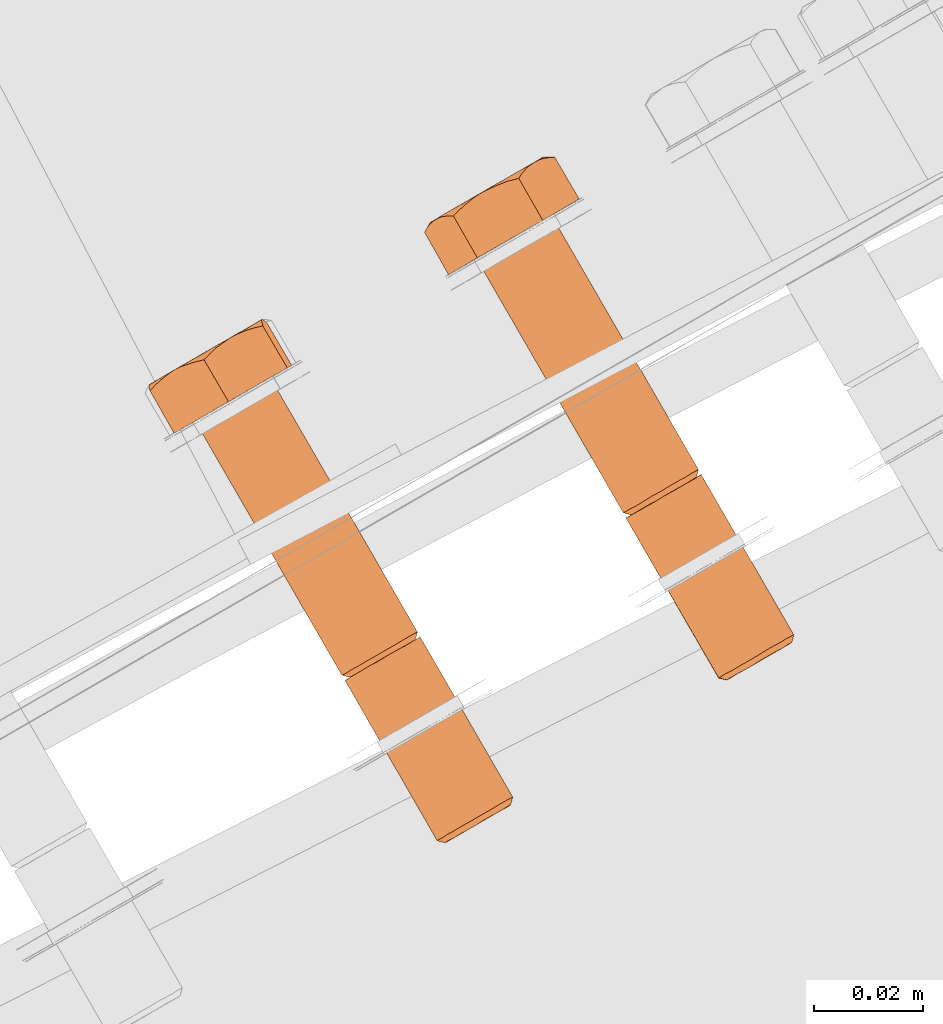
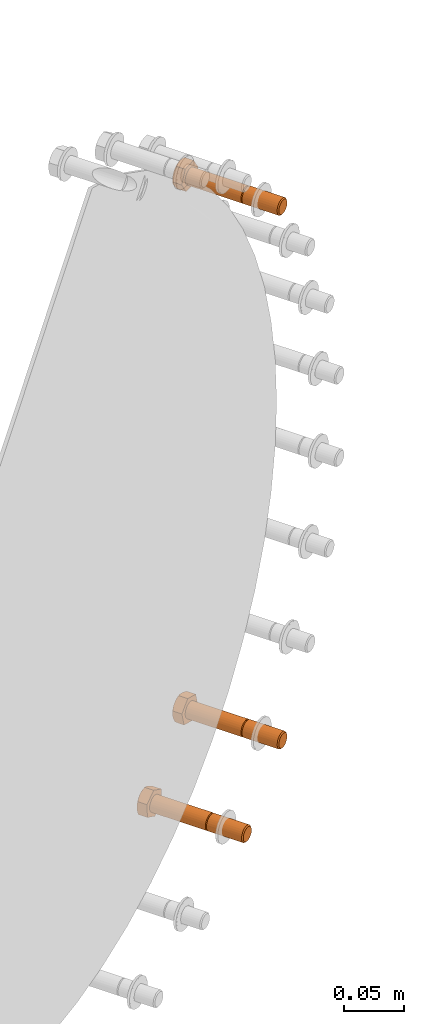
# One storey, part 79 of 126: 3 proxies.
"""IFC2X3 building model written with IfcOpenShell, lengths in millimetres."""

from ifc_helpers import new_model, si_unit, origin, origin_with_axes, place, context, project, spatial, faceted_brep, material, element, save


model = new_model("IFC2X3")

# Units and contexts
context_of_model_1 = context(None, 3, precision=0.1, world=origin())
context_of_model_2 = context(None, 3, precision=0.1, world=origin())
ifc_project = project(units=[si_unit("LENGTHUNIT", "METRE", prefix="MILLI"), si_unit("AREAUNIT", "SQUARE_METRE", prefix="CENTI"), si_unit("VOLUMEUNIT", "CUBIC_METRE", prefix="CENTI"), si_unit("MASSUNIT", "GRAM", prefix="KILO")], contexts=[context_of_model_1, context_of_model_2])

# Site, building, storey
site_placement = place(None, origin_with_axes())
site = spatial("IfcSite", under=ifc_project, at=site_placement, CompositionType="ELEMENT")
building_placement = place(site_placement, origin_with_axes())
building = spatial("IfcBuilding", under=site, at=building_placement, CompositionType="ELEMENT")
storey_placement = place(building_placement, origin_with_axes())
storey = spatial("IfcBuildingStorey", under=building, at=storey_placement, CompositionType="ELEMENT")

# Proxies
ifc_material = material(Name="STAHL")
proxy_1_placement = place(storey_placement, origin_with_axes())
element("IfcBuildingElementProxy", 1, at=proxy_1_placement, inside=storey, material=ifc_material, Name="profile", context=context_of_model_2, shape_type="Brep", body=[
    faceted_brep([(4323.5, 15061.4, 1171.5), (4322.7, 15061.0, 1173.2), (4322.5, 15059.6, 1172.6), (4323.1, 15060.0, 1171.1), (4323.9, 15061.6, 1169.6), (4323.5, 15060.1, 1169.5), (4323.8, 15061.6, 1167.7), (4323.4, 15060.1, 1167.9), (4323.4, 15061.4, 1165.8), (4323.1, 15059.9, 1166.2), (4322.6, 15060.9, 1164.1), (4322.4, 15059.5, 1164.8), (4321.5, 15060.2, 1162.7), (4321.4, 15059.0, 1163.5), (4320.1, 15059.4, 1161.7), (4320.2, 15058.3, 1162.6), (4318.5, 15058.5, 1161.0), (4318.9, 15057.5, 1162.0), (4316.9, 15057.6, 1160.8), (4317.4, 15056.7, 1161.9), (4315.2, 15056.6, 1161.1), (4316.0, 15055.8, 1162.1), (4313.7, 15055.7, 1161.8), (4314.6, 15055.1, 1162.7), (4312.3, 15054.9, 1162.9), (4313.5, 15054.4, 1163.7), (4311.2, 15054.3, 1164.3), (4312.5, 15053.8, 1164.9), (4306.0, 15091.7, 1171.5), (4305.2, 15091.3, 1173.2), (4305.0, 15089.9, 1172.6), (4305.6, 15090.3, 1171.1), (4306.4, 15091.9, 1169.6), (4306.0, 15090.5, 1169.5), (4306.3, 15091.9, 1167.7), (4305.9, 15090.4, 1167.9), (4305.9, 15091.7, 1165.8), (4305.6, 15090.2, 1166.2), (4305.1, 15091.2, 1164.1), (4304.9, 15089.8, 1164.8), (4304.0, 15090.6, 1162.7), (4303.9, 15089.3, 1163.5), (4302.6, 15089.8, 1161.7), (4302.7, 15088.6, 1162.6), (4301.0, 15088.9, 1161.0), (4301.4, 15087.8, 1162.0), (4299.4, 15087.9, 1160.8), (4299.9, 15087.0, 1161.9), (4297.7, 15086.9, 1161.1), (4298.5, 15086.1, 1162.1), (4296.2, 15086.0, 1161.8), (4297.1, 15085.4, 1162.7), (4294.8, 15085.3, 1162.9), (4296.0, 15084.7, 1163.7), (4293.7, 15084.6, 1164.3), (4295.0, 15084.1, 1164.9), (4310.5, 15053.9, 1166.1), (4293.5, 15083.3, 1166.1), (4294.3, 15083.7, 1164.3), (4310.1, 15053.7, 1167.9), (4293.1, 15083.0, 1167.9), (4310.1, 15053.7, 1169.9), (4293.1, 15083.1, 1169.9), (4310.5, 15053.9, 1171.7), (4293.6, 15083.3, 1171.7), (4311.3, 15054.4, 1173.4), (4294.4, 15083.8, 1173.4), (4312.5, 15055.0, 1174.9), (4295.5, 15084.4, 1174.9), (4313.8, 15055.8, 1175.9), (4296.9, 15085.2, 1175.9), (4315.4, 15056.7, 1176.6), (4298.5, 15086.1, 1176.6), (4317.1, 15057.7, 1176.8), (4300.1, 15087.1, 1176.8), (4318.7, 15058.7, 1176.5), (4301.8, 15088.0, 1176.5), (4320.3, 15059.6, 1175.8), (4303.3, 15088.9, 1175.8), (4321.6, 15060.3, 1174.7), (4304.7, 15089.7, 1174.7), (4305.8, 15090.3, 1173.2), (4279.0, 15138.4, 1171.5), (4278.3, 15138.0, 1173.2), (4279.4, 15138.6, 1169.6), (4279.4, 15138.6, 1167.7), (4279.0, 15138.4, 1165.8), (4278.2, 15137.9, 1164.1), (4277.0, 15137.3, 1162.7), (4275.6, 15136.5, 1161.7), (4274.1, 15135.5, 1161.0), (4272.4, 15134.6, 1160.8), (4270.8, 15133.6, 1161.1), (4269.2, 15132.7, 1161.8), (4267.8, 15132.0, 1162.9), (4266.8, 15131.3, 1164.3), (4304.1, 15090.6, 1174.7), (4277.2, 15137.3, 1174.7), (4275.8, 15136.6, 1175.8), (4302.8, 15089.9, 1175.8), (4293.0, 15084.2, 1166.1), (4266.0, 15130.9, 1166.1), (4292.6, 15084.0, 1167.9), (4265.6, 15130.7, 1167.9), (4292.6, 15084.0, 1169.9), (4265.6, 15130.7, 1169.9), (4293.0, 15084.2, 1171.7), (4266.1, 15130.9, 1171.7), (4293.8, 15084.7, 1173.4), (4266.9, 15131.4, 1173.4), (4295.0, 15085.3, 1174.9), (4268.0, 15132.0, 1174.9), (4296.3, 15086.1, 1175.9), (4269.4, 15132.8, 1175.9), (4297.9, 15087.1, 1176.6), (4271.0, 15133.7, 1176.6), (4299.6, 15088.0, 1176.8), (4272.6, 15134.7, 1176.8), (4301.2, 15089.0, 1176.5), (4274.3, 15135.7, 1176.5), (4260.5, 15127.7, 1167.9), (4267.2, 15131.6, 1156.4), (4279.2, 15138.5, 1157.3), (4284.5, 15141.6, 1169.7), (4277.8, 15137.7, 1181.2), (4265.8, 15130.8, 1180.3), (4261.4, 15138.5, 1180.3), (4260.4, 15138.5, 1178.5), (4259.5, 15138.4, 1176.8), (4258.8, 15138.2, 1175.5), (4258.2, 15137.9, 1174.1), (4257.5, 15137.4, 1172.4), (4256.9, 15136.8, 1170.7), (4256.5, 15136.2, 1169.3), (4256.1, 15135.5, 1167.9), (4257.5, 15137.5, 1172.1), (4257.2, 15137.3, 1170.1), (4257.1, 15137.3, 1168.0), (4257.4, 15137.5, 1165.9), (4258.0, 15137.8, 1164.0), (4258.2, 15137.8, 1163.4), (4257.5, 15137.3, 1164.7), (4256.8, 15136.5, 1166.2), (4258.9, 15138.3, 1162.1), (4262.6, 15139.7, 1180.4), (4263.7, 15140.7, 1180.5), (4265.2, 15141.9, 1180.6), (4266.8, 15142.9, 1180.8), (4265.0, 15141.9, 1180.4), (4263.3, 15140.9, 1179.8), (4261.7, 15140.0, 1178.8), (4260.3, 15139.2, 1177.5), (4259.1, 15138.5, 1175.9), (4268.2, 15143.6, 1180.9), (4269.6, 15144.2, 1181.0), (4271.4, 15144.9, 1181.1), (4273.4, 15145.4, 1181.2), (4273.9, 15146.2, 1179.9), (4274.5, 15146.9, 1178.6), (4275.3, 15147.7, 1177.0), (4276.2, 15148.3, 1175.5), (4275.0, 15147.6, 1177.1), (4273.7, 15146.9, 1178.5), (4272.1, 15146.0, 1179.6), (4270.4, 15145.0, 1180.3), (4268.6, 15144.0, 1180.7), (4259.8, 15138.8, 1160.5), (4260.9, 15139.1, 1159.0), (4261.8, 15139.2, 1157.7), (4262.7, 15139.3, 1156.4), (4264.2, 15140.7, 1156.5), (4265.7, 15142.0, 1156.6), (4266.9, 15142.9, 1156.7), (4268.2, 15143.7, 1156.8), (4269.9, 15144.6, 1156.9), (4271.6, 15145.3, 1157.1), (4273.1, 15145.8, 1157.2), (4274.7, 15146.2, 1157.3), (4276.8, 15148.7, 1163.5), (4277.5, 15149.1, 1165.4), (4277.8, 15149.3, 1167.5), (4277.9, 15149.3, 1169.6), (4277.6, 15149.1, 1171.6), (4277.0, 15148.8, 1173.6), (4276.9, 15148.7, 1174.2), (4277.7, 15149.0, 1172.9), (4278.8, 15149.2, 1171.3), (4280.0, 15149.3, 1169.7), (4279.2, 15149.3, 1168.3), (4278.5, 15149.2, 1166.9), (4277.6, 15149.0, 1165.2), (4270.0, 15144.7, 1157.1), (4271.7, 15145.7, 1157.8), (4273.3, 15146.6, 1158.8), (4274.7, 15147.5, 1160.1), (4275.9, 15148.1, 1161.7), (4275.8, 15147.8, 1160.8), (4275.2, 15147.1, 1159.1), (4276.3, 15148.3, 1162.1), (4260.0, 15139.0, 1160.5), (4261.4, 15139.8, 1159.1), (4262.9, 15140.7, 1158.0), (4264.6, 15141.6, 1157.3), (4266.4, 15142.7, 1156.9), (4296.1, 15084.8, 1174.0), (4295.1, 15084.2, 1172.8), (4294.4, 15083.8, 1171.3), (4294.1, 15083.6, 1169.7), (4294.1, 15083.6, 1168.1), (4294.4, 15083.8, 1166.4), (4304.1, 15089.3, 1173.9), (4302.9, 15088.7, 1174.9), (4301.5, 15087.9, 1175.5), (4300.1, 15087.1, 1175.7), (4298.7, 15086.2, 1175.5), (4297.3, 15085.5, 1175.0), (4306.5, 15090.8, 1171.5), (4306.9, 15091.0, 1169.6), (4306.9, 15091.0, 1167.7), (4306.5, 15090.7, 1165.8), (4305.7, 15090.3, 1164.1), (4304.5, 15089.6, 1162.7), (4303.1, 15088.8, 1161.7), (4301.6, 15087.9, 1161.0), (4299.9, 15087.0, 1160.8), (4298.3, 15086.0, 1161.1), (4296.7, 15085.1, 1161.8), (4295.3, 15084.3, 1162.9), (4311.6, 15053.3, 1168.1), (4311.9, 15053.5, 1166.4), (4321.6, 15059.0, 1173.9), (4320.4, 15058.4, 1174.9), (4319.0, 15057.6, 1175.5), (4317.6, 15056.8, 1175.7), (4316.2, 15055.9, 1175.5), (4314.8, 15055.1, 1175.0), (4313.6, 15054.5, 1174.0), (4312.6, 15053.9, 1172.8), (4311.9, 15053.5, 1171.3), (4311.6, 15053.3, 1169.7)], [[[0, 1, 2, 3]], [[4, 0, 3, 5]], [[6, 4, 5, 7]], [[8, 6, 7, 9]], [[10, 8, 9, 11]], [[12, 10, 11, 13]], [[14, 12, 13, 15]], [[16, 14, 15, 17]], [[18, 16, 17, 19]], [[20, 18, 19, 21]], [[22, 20, 21, 23]], [[24, 22, 23, 25]], [[26, 24, 25, 27]], [[28, 29, 30, 31]], [[32, 28, 31, 33]], [[34, 32, 33, 35]], [[36, 34, 35, 37]], [[38, 36, 37, 39]], [[40, 38, 39, 41]], [[42, 40, 41, 43]], [[44, 42, 43, 45]], [[46, 44, 45, 47]], [[48, 46, 47, 49]], [[50, 48, 49, 51]], [[52, 50, 51, 53]], [[54, 52, 53, 55]], [[26, 56, 57, 58]], [[56, 59, 60, 57]], [[59, 61, 62, 60]], [[61, 63, 64, 62]], [[63, 65, 66, 64]], [[65, 67, 68, 66]], [[67, 69, 70, 68]], [[69, 71, 72, 70]], [[71, 73, 74, 72]], [[73, 75, 76, 74]], [[75, 77, 78, 76]], [[77, 79, 80, 78]], [[1, 81, 80, 79]], [[29, 28, 82, 83]], [[28, 32, 84, 82]], [[32, 34, 85, 84]], [[34, 36, 86, 85]], [[36, 38, 87, 86]], [[38, 40, 88, 87]], [[40, 42, 89, 88]], [[42, 44, 90, 89]], [[44, 46, 91, 90]], [[46, 48, 92, 91]], [[48, 50, 93, 92]], [[50, 52, 94, 93]], [[52, 54, 95, 94]], [[96, 97, 98, 99]], [[29, 83, 97, 96]], [[54, 100, 101, 95]], [[102, 103, 101, 100]], [[104, 105, 103, 102]], [[106, 107, 105, 104]], [[108, 109, 107, 106]], [[110, 111, 109, 108]], [[112, 113, 111, 110]], [[114, 115, 113, 112]], [[116, 117, 115, 114]], [[118, 119, 117, 116]], [[99, 98, 119, 118]], [[120, 121, 122, 123, 86, 87, 88, 89, 90, 91, 92, 93, 94, 95, 101, 103, 105, 107, 109, 111, 113, 115, 117, 119, 98, 97, 83, 82, 84, 85, 86, 123, 124, 125]], [[120, 125, 126, 127, 128, 129, 130, 131, 132, 133, 134]], [[134, 133, 132, 131, 130, 135, 136, 137, 138, 139, 140, 141, 142]], [[143, 140, 139]], [[128, 127, 126, 144, 145, 146, 147, 148, 149, 150, 151, 152]], [[129, 128, 152]], [[130, 129, 152]], [[153, 154, 155, 156, 157, 158, 159, 160, 161, 162, 163, 164, 165]], [[147, 153, 165]], [[120, 134, 142, 141, 140, 143, 166, 167, 168, 169, 121]], [[121, 169, 170, 171, 172, 173, 174, 175, 176, 177, 122]], [[178, 179, 180, 181, 182, 183, 184, 185, 186, 187, 188, 189, 190]], [[160, 184, 183]], [[173, 191, 192, 193, 194, 195, 196, 197, 177, 176, 175, 174]], [[198, 196, 195]], [[178, 198, 195]], [[143, 199, 200, 201, 202, 203, 172, 171, 170, 169, 168, 167, 166]], [[173, 172, 203]], [[122, 177, 197, 196, 198, 178, 190, 189, 188, 187, 123]], [[124, 123, 187, 186, 185, 184, 160, 159, 158, 157, 156]], [[125, 124, 156, 155, 154, 153, 147, 146, 145, 144, 126]], [[137, 136, 135, 130, 152, 151, 150, 149, 148, 147, 165, 164, 163, 162, 161, 160, 183, 182, 181, 180, 179, 178, 195, 194, 193, 192, 191, 173, 203, 202, 201, 200, 199, 143, 139, 138]], [[60, 62, 64, 66, 204, 205, 206, 207, 208, 209, 55, 53, 51, 49, 47, 45, 43, 41, 39, 37, 35, 33, 31, 30, 210, 211, 212, 213, 214, 215, 204, 66, 68, 70, 72, 74, 76, 78, 80, 81, 216, 217, 218, 219, 220, 221, 222, 223, 224, 225, 226, 227, 58, 57]], [[100, 54, 55, 209]], [[102, 100, 209, 208]], [[104, 102, 208, 207]], [[106, 104, 207, 206]], [[108, 106, 206, 205]], [[110, 108, 205, 204]], [[112, 110, 204, 215]], [[114, 112, 215, 214]], [[116, 114, 214, 213]], [[118, 116, 213, 212]], [[99, 118, 212, 211]], [[96, 99, 211, 210]], [[30, 29, 96, 210]], [[26, 58, 227, 24]], [[0, 216, 81, 1]], [[4, 217, 216, 0]], [[6, 218, 217, 4]], [[8, 219, 218, 6]], [[10, 220, 219, 8]], [[12, 221, 220, 10]], [[14, 222, 221, 12]], [[16, 223, 222, 14]], [[18, 224, 223, 16]], [[20, 225, 224, 18]], [[22, 226, 225, 20]], [[24, 227, 226, 22]], [[228, 229, 27, 25, 23, 21, 19, 17, 15, 13, 11, 9, 7, 5, 3, 2, 230, 231, 232, 233, 234, 235, 236, 237, 238, 239]], [[56, 26, 27, 229]], [[59, 56, 229, 228]], [[61, 59, 228, 239]], [[63, 61, 239, 238]], [[65, 63, 238, 237]], [[67, 65, 237, 236]], [[69, 67, 236, 235]], [[71, 69, 235, 234]], [[73, 71, 234, 233]], [[75, 73, 233, 232]], [[77, 75, 232, 231]], [[79, 77, 231, 230]], [[1, 79, 230, 2]]]),
])
proxy_2_placement = place(storey_placement, origin_with_axes())
element("IfcBuildingElementProxy", 2, at=proxy_2_placement, inside=storey, material=ifc_material, Name="profile", context=context_of_model_2, shape_type="Brep", body=[
    faceted_brep([(4320.6, 15058.5, 617.3), (4320.6, 15059.7, 616.4), (4321.9, 15060.5, 617.6), (4321.7, 15059.2, 618.3), (4319.3, 15057.7, 616.6), (4319.0, 15058.8, 615.6), (4317.9, 15056.9, 616.3), (4317.4, 15057.9, 615.2), (4316.4, 15056.1, 616.4), (4315.7, 15056.9, 615.3), (4315.1, 15055.3, 616.9), (4314.1, 15056.0, 615.9), (4313.8, 15054.6, 617.8), (4312.7, 15055.2, 616.9), (4312.8, 15054.0, 618.9), (4311.5, 15054.5, 618.3), (4312.0, 15053.6, 620.4), (4310.7, 15054.0, 619.9), (4311.6, 15053.3, 622.0), (4310.2, 15053.7, 621.8), (4311.5, 15053.3, 623.6), (4310.1, 15053.6, 623.7), (4311.8, 15053.4, 625.3), (4310.4, 15053.8, 625.6), (4312.4, 15053.7, 626.8), (4311.0, 15054.2, 627.3), (4313.3, 15054.3, 628.1), (4312.1, 15054.8, 628.9), (4303.1, 15088.8, 617.3), (4303.1, 15090.0, 616.4), (4304.4, 15090.8, 617.6), (4304.2, 15089.5, 618.3), (4301.8, 15088.0, 616.6), (4301.5, 15089.1, 615.6), (4300.4, 15087.2, 616.3), (4299.9, 15088.2, 615.2), (4298.9, 15086.4, 616.4), (4298.2, 15087.2, 615.3), (4297.6, 15085.6, 616.9), (4296.6, 15086.3, 615.9), (4296.3, 15084.9, 617.8), (4295.2, 15085.5, 616.9), (4295.3, 15084.3, 618.9), (4294.0, 15084.8, 618.3), (4294.5, 15083.9, 620.4), (4293.2, 15084.3, 619.9), (4294.1, 15083.6, 622.0), (4292.7, 15084.0, 621.8), (4294.0, 15083.6, 623.6), (4292.6, 15084.0, 623.7), (4294.3, 15083.7, 625.3), (4292.9, 15084.1, 625.6), (4294.9, 15084.1, 626.8), (4293.5, 15084.5, 627.3), (4295.8, 15084.6, 628.1), (4294.6, 15085.1, 628.9), (4313.4, 15055.6, 630.1), (4296.4, 15084.9, 630.1), (4295.1, 15084.2, 628.9), (4314.9, 15056.5, 630.8), (4298.0, 15085.8, 630.8), (4316.6, 15057.4, 631.2), (4299.6, 15086.8, 631.2), (4318.2, 15058.4, 631.1), (4301.3, 15087.7, 631.1), (4319.8, 15059.3, 630.5), (4302.9, 15088.7, 630.5), (4321.2, 15060.1, 629.5), (4304.3, 15089.5, 629.5), (4322.4, 15060.8, 628.1), (4305.5, 15090.2, 628.1), (4323.3, 15061.3, 626.5), (4306.3, 15090.7, 626.5), (4323.8, 15061.6, 624.7), (4306.8, 15091.0, 624.7), (4323.9, 15061.6, 622.7), (4306.9, 15091.0, 622.7), (4323.6, 15061.5, 620.8), (4306.6, 15090.8, 620.8), (4322.9, 15061.1, 619.1), (4305.9, 15090.4, 619.1), (4304.9, 15089.8, 617.6), (4276.1, 15136.7, 616.4), (4277.4, 15137.5, 617.6), (4274.6, 15135.8, 615.6), (4272.9, 15134.9, 615.2), (4271.3, 15133.9, 615.3), (4269.7, 15133.0, 615.9), (4268.2, 15132.2, 616.9), (4267.1, 15131.5, 618.3), (4266.2, 15131.0, 619.9), (4265.7, 15130.7, 621.8), (4265.6, 15130.7, 623.7), (4265.9, 15130.8, 625.6), (4266.6, 15131.2, 627.3), (4267.6, 15131.8, 628.9), (4295.9, 15085.9, 630.1), (4268.9, 15132.6, 630.1), (4297.4, 15086.8, 630.8), (4270.5, 15133.5, 630.8), (4299.1, 15087.7, 631.2), (4272.1, 15134.4, 631.2), (4300.7, 15088.7, 631.1), (4273.8, 15135.4, 631.1), (4302.3, 15089.6, 630.5), (4275.4, 15136.3, 630.5), (4303.7, 15090.4, 629.5), (4276.8, 15137.1, 629.5), (4304.9, 15091.1, 628.1), (4278.0, 15137.8, 628.1), (4305.8, 15091.6, 626.5), (4278.8, 15138.3, 626.5), (4306.3, 15091.9, 624.7), (4279.3, 15138.6, 624.7), (4306.4, 15091.9, 622.7), (4279.4, 15138.6, 622.7), (4306.1, 15091.8, 620.8), (4279.1, 15138.5, 620.8), (4305.4, 15091.4, 619.1), (4278.4, 15138.1, 619.1), (4260.9, 15128.0, 626.8), (4264.0, 15129.7, 613.4), (4275.6, 15136.4, 609.8), (4284.1, 15141.3, 619.6), (4281.0, 15139.5, 633.0), (4269.4, 15132.9, 636.6), (4276.5, 15147.3, 633.0), (4274.6, 15146.8, 633.5), (4272.8, 15146.1, 634.0), (4271.5, 15145.5, 634.4), (4270.2, 15144.9, 634.8), (4268.7, 15143.9, 635.3), (4267.2, 15142.7, 635.8), (4266.1, 15141.7, 636.2), (4264.9, 15140.6, 636.6), (4261.1, 15139.6, 632.8), (4262.1, 15140.0, 633.8), (4263.5, 15140.3, 635.2), (4268.4, 15143.8, 635.2), (4266.6, 15142.8, 635.2), (4264.8, 15141.8, 634.8), (4263.1, 15140.8, 634.1), (4261.6, 15139.9, 633.0), (4260.2, 15139.1, 631.7), (4271.9, 15145.8, 634.1), (4276.7, 15147.9, 631.5), (4276.9, 15148.3, 630.0), (4277.2, 15148.8, 628.1), (4277.6, 15149.1, 626.3), (4276.9, 15148.7, 628.3), (4276.0, 15148.2, 630.1), (4274.9, 15147.6, 631.7), (4273.5, 15146.7, 633.0), (4274.9, 15147.6, 614.7), (4276.0, 15148.2, 616.3), (4276.9, 15148.7, 618.1), (4277.6, 15149.1, 620.1), (4277.9, 15149.3, 622.2), (4277.9, 15149.3, 624.3), (4277.9, 15149.3, 624.9), (4278.3, 15149.3, 623.4), (4278.9, 15149.3, 621.5), (4279.6, 15149.1, 619.6), (4278.5, 15148.9, 618.5), (4277.4, 15148.6, 617.4), (4276.1, 15148.1, 616.1), (4259.0, 15138.3, 630.4), (4258.0, 15137.4, 629.0), (4257.2, 15136.6, 627.9), (4256.5, 15135.7, 626.8), (4256.6, 15136.4, 624.9), (4256.9, 15136.9, 623.0), (4257.2, 15137.3, 621.6), (4257.5, 15137.5, 620.1), (4257.9, 15137.7, 618.3), (4258.5, 15137.7, 616.5), (4259.0, 15137.6, 615.0), (4259.6, 15137.5, 613.4), (4264.8, 15141.8, 611.6), (4266.6, 15142.8, 611.3), (4268.4, 15143.8, 611.3), (4270.2, 15144.9, 611.6), (4271.9, 15145.8, 612.3), (4273.5, 15146.7, 613.4), (4274.0, 15147.0, 613.6), (4273.1, 15146.3, 612.6), (4272.1, 15145.3, 611.2), (4271.2, 15144.2, 609.8), (4269.6, 15143.8, 610.2), (4268.2, 15143.3, 610.6), (4266.4, 15142.6, 611.1), (4258.1, 15137.9, 618.1), (4259.0, 15138.4, 616.3), (4260.2, 15139.1, 614.7), (4261.6, 15139.9, 613.4), (4263.1, 15140.8, 612.3), (4263.6, 15141.0, 612.0), (4262.4, 15140.1, 612.4), (4261.0, 15138.9, 612.9), (4259.0, 15138.4, 630.1), (4258.1, 15137.9, 628.3), (4257.5, 15137.5, 626.3), (4257.2, 15137.3, 624.3), (4257.2, 15137.3, 622.2), (4293.1, 15083.0, 623.7), (4293.4, 15083.2, 625.6), (4294.1, 15083.6, 627.3), (4303.6, 15089.1, 616.4), (4305.1, 15090.0, 619.6), (4305.7, 15090.3, 621.2), (4306.0, 15090.5, 622.8), (4305.9, 15090.4, 624.5), (4305.5, 15090.2, 626.1), (4304.7, 15089.7, 627.5), (4303.7, 15089.1, 628.7), (4302.5, 15088.4, 629.5), (4301.1, 15087.6, 630.0), (4299.7, 15086.8, 630.1), (4298.2, 15086.0, 629.8), (4296.9, 15085.2, 629.1), (4302.1, 15088.2, 615.6), (4300.4, 15087.3, 615.2), (4298.8, 15086.3, 615.3), (4297.2, 15085.4, 615.9), (4295.7, 15084.5, 616.9), (4294.6, 15083.9, 618.3), (4293.7, 15083.4, 619.9), (4293.2, 15083.1, 621.8), (4322.6, 15059.7, 619.6), (4323.2, 15060.0, 621.2), (4323.5, 15060.2, 622.8), (4323.4, 15060.1, 624.5), (4323.0, 15059.9, 626.1), (4322.2, 15059.4, 627.5), (4321.2, 15058.8, 628.7), (4320.0, 15058.1, 629.5), (4318.6, 15057.3, 630.0), (4317.2, 15056.5, 630.1), (4315.7, 15055.7, 629.8), (4314.4, 15054.9, 629.1)], [[[0, 1, 2, 3]], [[4, 5, 1, 0]], [[6, 7, 5, 4]], [[8, 9, 7, 6]], [[10, 11, 9, 8]], [[12, 13, 11, 10]], [[14, 15, 13, 12]], [[16, 17, 15, 14]], [[18, 19, 17, 16]], [[20, 21, 19, 18]], [[22, 23, 21, 20]], [[24, 25, 23, 22]], [[26, 27, 25, 24]], [[28, 29, 30, 31]], [[32, 33, 29, 28]], [[34, 35, 33, 32]], [[36, 37, 35, 34]], [[38, 39, 37, 36]], [[40, 41, 39, 38]], [[42, 43, 41, 40]], [[44, 45, 43, 42]], [[46, 47, 45, 44]], [[48, 49, 47, 46]], [[50, 51, 49, 48]], [[52, 53, 51, 50]], [[54, 55, 53, 52]], [[27, 56, 57, 58]], [[56, 59, 60, 57]], [[59, 61, 62, 60]], [[61, 63, 64, 62]], [[63, 65, 66, 64]], [[65, 67, 68, 66]], [[67, 69, 70, 68]], [[69, 71, 72, 70]], [[71, 73, 74, 72]], [[73, 75, 76, 74]], [[75, 77, 78, 76]], [[77, 79, 80, 78]], [[79, 2, 81, 80]], [[29, 82, 83, 30]], [[29, 33, 84, 82]], [[33, 35, 85, 84]], [[35, 37, 86, 85]], [[37, 39, 87, 86]], [[39, 41, 88, 87]], [[41, 43, 89, 88]], [[43, 45, 90, 89]], [[45, 47, 91, 90]], [[47, 49, 92, 91]], [[49, 51, 93, 92]], [[51, 53, 94, 93]], [[53, 55, 95, 94]], [[96, 97, 95, 55]], [[96, 98, 99, 97]], [[98, 100, 101, 99]], [[100, 102, 103, 101]], [[102, 104, 105, 103]], [[104, 106, 107, 105]], [[106, 108, 109, 107]], [[108, 110, 111, 109]], [[110, 112, 113, 111]], [[112, 114, 115, 113]], [[114, 116, 117, 115]], [[116, 118, 119, 117]], [[118, 30, 83, 119]], [[120, 121, 122, 86, 87, 88, 89, 90, 91, 92, 93, 94, 95, 97, 99, 101, 103, 105, 107, 109, 111, 113, 115, 117, 119, 83, 82, 84, 85, 86, 122, 123, 124, 125]], [[125, 124, 126, 127, 128, 129, 130, 131, 132, 133, 134]], [[135, 136, 137, 134, 133, 132, 131, 130, 138, 139, 140, 141, 142]], [[143, 135, 142]], [[144, 128, 127, 126, 145, 146, 147, 148, 149, 150, 151, 152]], [[129, 128, 144]], [[130, 129, 144]], [[153, 154, 155, 156, 157, 158, 159, 160, 161, 162, 163, 164, 165]], [[148, 159, 158]], [[120, 125, 134, 137, 136, 135, 143, 166, 167, 168, 169]], [[120, 169, 170, 171, 172, 173, 174, 175, 176, 177, 121]], [[178, 179, 180, 181, 182, 183, 184, 185, 186, 187, 188, 189, 190]], [[153, 184, 183]], [[173, 191, 192, 193, 194, 195, 196, 197, 198, 177, 176, 175, 174]], [[178, 196, 195]], [[169, 168, 167, 166, 143, 199, 200, 201, 202, 203, 172, 171, 170]], [[173, 172, 203]], [[121, 177, 198, 197, 196, 178, 190, 189, 188, 187, 122]], [[122, 187, 186, 185, 184, 153, 165, 164, 163, 162, 123]], [[124, 123, 162, 161, 160, 159, 148, 147, 146, 145, 126]], [[202, 201, 200, 199, 143, 142, 141, 140, 139, 138, 130, 144, 152, 151, 150, 149, 148, 158, 157, 156, 155, 154, 153, 183, 182, 181, 180, 179, 178, 195, 194, 193, 192, 191, 173, 203]], [[204, 205, 206, 58, 57, 60, 62, 64, 66, 68, 70, 72, 74, 76, 78, 80, 81, 207, 28, 31, 208, 209, 210, 211, 212, 213, 214, 215, 216, 217, 218, 219, 54, 52, 50, 48, 46, 44, 42, 40, 38, 36, 34, 32, 28, 207, 220, 221, 222, 223, 224, 225, 226, 227]], [[96, 55, 54, 219]], [[98, 96, 219, 218]], [[100, 98, 218, 217]], [[102, 100, 217, 216]], [[104, 102, 216, 215]], [[106, 104, 215, 214]], [[108, 106, 214, 213]], [[110, 108, 213, 212]], [[112, 110, 212, 211]], [[114, 112, 211, 210]], [[116, 114, 210, 209]], [[118, 116, 209, 208]], [[31, 30, 118, 208]], [[2, 1, 207, 81]], [[1, 5, 220, 207]], [[5, 7, 221, 220]], [[7, 9, 222, 221]], [[9, 11, 223, 222]], [[11, 13, 224, 223]], [[13, 15, 225, 224]], [[15, 17, 226, 225]], [[17, 19, 227, 226]], [[19, 21, 204, 227]], [[21, 23, 205, 204]], [[23, 25, 206, 205]], [[25, 27, 58, 206]], [[20, 18, 16, 14, 12, 10, 8, 6, 4, 0, 3, 228, 229, 230, 231, 232, 233, 234, 235, 236, 237, 238, 239, 26, 24, 22]], [[239, 56, 27, 26]], [[238, 59, 56, 239]], [[237, 61, 59, 238]], [[236, 63, 61, 237]], [[235, 65, 63, 236]], [[234, 67, 65, 235]], [[233, 69, 67, 234]], [[232, 71, 69, 233]], [[231, 73, 71, 232]], [[230, 75, 73, 231]], [[229, 77, 75, 230]], [[228, 79, 77, 229]], [[3, 2, 79, 228]]]),
])
proxy_3_placement = place(storey_placement, origin_with_axes())
element("IfcBuildingElementProxy", 3, at=proxy_3_placement, inside=storey, material=ifc_material, Name="profile", context=context_of_model_2, shape_type="Brep", body=[
    faceted_brep([(4267.7, 15029.2, 556.1), (4269.2, 15030.1, 557.0), (4269.2, 15028.8, 557.9), (4267.9, 15028.1, 557.1), (4266.1, 15028.3, 555.7), (4266.5, 15027.3, 556.7), (4264.4, 15027.3, 555.7), (4265.1, 15026.4, 556.8), (4262.8, 15026.4, 556.2), (4263.7, 15025.6, 557.2), (4261.3, 15025.5, 557.1), (4262.4, 15024.9, 558.0), (4260.1, 15024.8, 558.4), (4261.3, 15024.3, 559.1), (4259.2, 15024.3, 560.0), (4260.5, 15023.8, 560.5), (4258.6, 15023.9, 561.8), (4260.1, 15023.5, 562.1), (4258.4, 15023.8, 563.7), (4259.9, 15023.4, 563.7), (4258.7, 15024.0, 565.6), (4260.1, 15023.6, 565.4), (4259.3, 15024.3, 567.4), (4260.6, 15023.9, 566.9), (4260.2, 15024.9, 569.0), (4261.5, 15024.3, 568.3), (4261.5, 15025.6, 570.3), (4262.6, 15025.0, 569.4), (4250.4, 15058.4, 557.1), (4250.2, 15059.5, 556.1), (4251.7, 15060.4, 557.0), (4251.7, 15059.1, 557.9), (4249.0, 15057.6, 556.7), (4248.6, 15058.6, 555.7), (4247.6, 15056.7, 556.8), (4246.9, 15057.6, 555.7), (4246.2, 15055.9, 557.2), (4245.3, 15056.7, 556.2), (4244.9, 15055.2, 558.0), (4243.8, 15055.8, 557.1), (4243.8, 15054.6, 559.1), (4242.6, 15055.1, 558.4), (4243.0, 15054.1, 560.5), (4241.7, 15054.6, 560.0), (4242.6, 15053.8, 562.1), (4241.1, 15054.3, 561.8), (4242.4, 15053.8, 563.7), (4240.9, 15054.2, 563.7), (4242.6, 15053.9, 565.4), (4241.2, 15054.3, 565.6), (4243.1, 15054.2, 566.9), (4241.8, 15054.6, 567.4), (4244.0, 15054.7, 568.3), (4242.7, 15055.2, 569.0), (4245.1, 15055.3, 569.4), (4244.0, 15055.9, 570.3), (4252.2, 15059.4, 557.0), (4253.5, 15060.2, 558.2), (4270.5, 15030.8, 558.2), (4263.0, 15026.5, 571.1), (4246.0, 15055.9, 571.1), (4244.5, 15055.0, 570.3), (4264.6, 15027.4, 571.6), (4247.7, 15056.8, 571.6), (4266.3, 15028.4, 571.5), (4249.3, 15057.8, 571.5), (4267.9, 15029.3, 571.0), (4250.9, 15058.7, 571.0), (4269.4, 15030.2, 570.1), (4252.4, 15059.5, 570.1), (4270.6, 15030.9, 568.8), (4253.6, 15060.2, 568.8), (4271.5, 15031.4, 567.2), (4254.6, 15060.8, 567.2), (4272.1, 15031.7, 565.4), (4255.1, 15061.1, 565.4), (4272.3, 15031.8, 563.5), (4255.3, 15061.2, 563.5), (4272.1, 15031.7, 561.6), (4255.1, 15061.1, 561.6), (4271.4, 15031.4, 559.8), (4254.5, 15060.7, 559.8), (4223.3, 15106.2, 556.1), (4224.7, 15107.1, 557.0), (4221.6, 15105.3, 555.7), (4220.0, 15104.3, 555.7), (4218.3, 15103.4, 556.2), (4216.9, 15102.5, 557.1), (4215.6, 15101.8, 558.4), (4214.7, 15101.3, 560.0), (4214.1, 15100.9, 561.8), (4214.0, 15100.8, 563.7), (4214.2, 15101.0, 565.6), (4214.8, 15101.3, 567.4), (4215.8, 15101.9, 569.0), (4217.0, 15102.6, 570.3), (4253.0, 15061.1, 558.2), (4226.0, 15107.8, 558.2), (4227.0, 15108.4, 559.8), (4253.9, 15061.7, 559.8), (4245.5, 15056.8, 571.1), (4218.5, 15103.5, 571.1), (4247.1, 15057.7, 571.6), (4220.2, 15104.4, 571.6), (4248.8, 15058.7, 571.5), (4221.8, 15105.4, 571.5), (4250.4, 15059.6, 571.0), (4223.4, 15106.3, 571.0), (4251.9, 15060.5, 570.1), (4224.9, 15107.2, 570.1), (4253.1, 15061.2, 568.8), (4226.1, 15107.9, 568.8), (4254.0, 15061.7, 567.2), (4227.1, 15108.4, 567.2), (4254.6, 15062.0, 565.4), (4227.6, 15108.7, 565.4), (4254.8, 15062.1, 563.5), (4227.8, 15108.8, 563.5), (4254.6, 15062.0, 561.6), (4227.6, 15108.7, 561.6), (4210.1, 15098.6, 569.7), (4210.9, 15099.1, 555.9), (4221.7, 15105.3, 549.8), (4231.7, 15111.1, 557.5), (4230.9, 15110.6, 571.3), (4220.1, 15104.4, 577.4), (4226.4, 15118.3, 571.3), (4224.6, 15117.9, 572.2), (4222.9, 15117.3, 573.0), (4221.7, 15116.8, 573.7), (4220.5, 15116.2, 574.4), (4219.1, 15115.2, 575.2), (4217.7, 15114.2, 576.0), (4216.7, 15113.2, 576.7), (4215.6, 15112.1, 577.4), (4211.2, 15110.8, 574.4), (4212.4, 15111.2, 575.3), (4214.0, 15111.7, 576.3), (4218.8, 15115.2, 575.1), (4217.0, 15114.2, 575.5), (4215.2, 15113.1, 575.6), (4213.4, 15112.1, 575.3), (4211.7, 15111.1, 574.6), (4210.1, 15110.2, 573.6), (4226.3, 15118.8, 569.7), (4226.2, 15119.1, 568.2), (4226.2, 15119.4, 566.3), (4226.3, 15119.5, 564.4), (4226.0, 15119.3, 566.5), (4225.4, 15119.0, 568.4), (4224.5, 15118.5, 570.3), (4223.4, 15117.8, 571.9), (4222.0, 15117.1, 573.3), (4221.7, 15116.8, 553.6), (4223.1, 15117.7, 554.9), (4224.3, 15118.3, 556.5), (4225.2, 15118.9, 558.3), (4225.9, 15119.3, 560.2), (4226.2, 15119.5, 562.3), (4226.5, 15119.4, 561.4), (4226.8, 15119.2, 559.5), (4227.2, 15118.8, 557.5), (4225.8, 15118.5, 556.6), (4224.6, 15118.1, 555.7), (4223.1, 15117.6, 554.7), (4226.4, 15119.5, 562.9), (4208.8, 15109.3, 572.5), (4207.6, 15108.3, 571.5), (4206.6, 15107.4, 570.6), (4205.7, 15106.4, 569.7), (4205.5, 15106.9, 567.7), (4205.5, 15107.2, 565.8), (4205.5, 15107.4, 564.3), (4205.5, 15107.5, 562.8), (4205.7, 15107.5, 560.9), (4205.9, 15107.4, 559.0), (4206.1, 15107.1, 557.5), (4206.5, 15106.8, 555.9), (4211.3, 15110.9, 552.8), (4213.0, 15111.8, 552.1), (4214.8, 15112.9, 551.7), (4216.6, 15113.9, 551.6), (4218.4, 15114.9, 551.9), (4220.1, 15115.9, 552.6), (4220.6, 15116.2, 552.8), (4219.6, 15115.4, 551.9), (4218.4, 15114.3, 550.9), (4217.2, 15113.0, 549.8), (4215.8, 15112.7, 550.5), (4214.4, 15112.3, 551.2), (4212.8, 15111.6, 552.0), (4205.8, 15107.7, 560.8), (4206.4, 15108.0, 558.8), (4207.3, 15108.5, 556.9), (4208.4, 15109.2, 555.3), (4209.7, 15110.0, 553.9), (4210.1, 15110.1, 553.5), (4209.1, 15109.3, 554.2), (4207.7, 15108.2, 555.0), (4208.7, 15109.4, 572.3), (4207.5, 15108.7, 570.7), (4206.6, 15108.1, 568.9), (4205.9, 15107.7, 567.0), (4205.6, 15107.5, 564.9), (4241.5, 15053.2, 563.7), (4241.7, 15053.3, 565.6), (4242.3, 15053.7, 567.4), (4243.3, 15054.3, 569.0), (4250.8, 15058.6, 556.1), (4252.8, 15059.8, 558.9), (4253.7, 15060.3, 560.3), (4254.2, 15060.6, 561.8), (4254.4, 15060.7, 563.5), (4254.2, 15060.6, 565.2), (4253.7, 15060.3, 566.7), (4252.9, 15059.8, 568.1), (4251.9, 15059.2, 569.2), (4250.6, 15058.5, 570.0), (4249.2, 15057.7, 570.5), (4247.8, 15056.8, 570.5), (4246.4, 15056.0, 570.1), (4249.1, 15057.6, 555.7), (4247.5, 15056.7, 555.7), (4245.8, 15055.7, 556.2), (4244.4, 15054.9, 557.1), (4243.1, 15054.2, 558.4), (4242.2, 15053.6, 560.0), (4241.6, 15053.3, 561.8), (4270.3, 15029.5, 558.9), (4271.2, 15029.9, 560.3), (4271.7, 15030.2, 561.8), (4271.9, 15030.4, 563.5), (4271.7, 15030.3, 565.2), (4271.2, 15030.0, 566.7), (4270.4, 15029.5, 568.1), (4269.4, 15028.9, 569.2), (4268.1, 15028.2, 570.0), (4266.7, 15027.4, 570.5), (4265.3, 15026.5, 570.5), (4263.9, 15025.7, 570.1)], [[[0, 1, 2, 3]], [[4, 0, 3, 5]], [[6, 4, 5, 7]], [[8, 6, 7, 9]], [[10, 8, 9, 11]], [[12, 10, 11, 13]], [[14, 12, 13, 15]], [[16, 14, 15, 17]], [[18, 16, 17, 19]], [[20, 18, 19, 21]], [[22, 20, 21, 23]], [[24, 22, 23, 25]], [[26, 24, 25, 27]], [[28, 29, 30, 31]], [[32, 33, 29, 28]], [[34, 35, 33, 32]], [[36, 37, 35, 34]], [[38, 39, 37, 36]], [[40, 41, 39, 38]], [[42, 43, 41, 40]], [[44, 45, 43, 42]], [[46, 47, 45, 44]], [[48, 49, 47, 46]], [[50, 51, 49, 48]], [[52, 53, 51, 50]], [[54, 55, 53, 52]], [[1, 56, 57, 58]], [[59, 60, 61, 26]], [[62, 63, 60, 59]], [[64, 65, 63, 62]], [[66, 67, 65, 64]], [[68, 69, 67, 66]], [[70, 71, 69, 68]], [[72, 73, 71, 70]], [[74, 75, 73, 72]], [[76, 77, 75, 74]], [[78, 79, 77, 76]], [[80, 81, 79, 78]], [[58, 57, 81, 80]], [[30, 29, 82, 83]], [[29, 33, 84, 82]], [[33, 35, 85, 84]], [[35, 37, 86, 85]], [[37, 39, 87, 86]], [[39, 41, 88, 87]], [[41, 43, 89, 88]], [[43, 45, 90, 89]], [[45, 47, 91, 90]], [[47, 49, 92, 91]], [[49, 51, 93, 92]], [[51, 53, 94, 93]], [[55, 95, 94, 53]], [[96, 97, 98, 99]], [[30, 83, 97, 96]], [[100, 101, 95, 55]], [[102, 103, 101, 100]], [[104, 105, 103, 102]], [[106, 107, 105, 104]], [[108, 109, 107, 106]], [[110, 111, 109, 108]], [[112, 113, 111, 110]], [[114, 115, 113, 112]], [[116, 117, 115, 114]], [[118, 119, 117, 116]], [[99, 98, 119, 118]], [[120, 121, 122, 86, 87, 88, 89, 90, 91, 92, 93, 94, 95, 101, 103, 105, 107, 109, 111, 113, 115, 117, 119, 98, 97, 83, 82, 84, 85, 86, 122, 123, 124, 125]], [[125, 124, 126, 127, 128, 129, 130, 131, 132, 133, 134]], [[135, 136, 137, 134, 133, 132, 131, 130, 138, 139, 140, 141, 142]], [[143, 135, 142]], [[129, 128, 127, 126, 144, 145, 146, 147, 148, 149, 150, 151, 152]], [[130, 129, 152]], [[153, 154, 155, 156, 157, 158, 159, 160, 161, 162, 163, 164]], [[165, 159, 158]], [[147, 165, 158]], [[120, 125, 134, 137, 136, 135, 143, 166, 167, 168, 169]], [[120, 169, 170, 171, 172, 173, 174, 175, 176, 177, 121]], [[178, 179, 180, 181, 182, 183, 184, 185, 186, 187, 188, 189, 190]], [[153, 184, 183]], [[177, 176, 175, 174, 173, 191, 192, 193, 194, 195, 196, 197, 198]], [[178, 196, 195]], [[169, 168, 167, 166, 143, 199, 200, 201, 202, 203, 171, 170]], [[172, 171, 203]], [[173, 172, 203]], [[121, 177, 198, 197, 196, 178, 190, 189, 188, 187, 122]], [[122, 187, 186, 185, 184, 153, 164, 163, 162, 161, 123]], [[124, 123, 161, 160, 159, 165, 147, 146, 145, 144, 126]], [[173, 203, 202, 201, 200, 199, 143, 142, 141, 140, 139, 138, 130, 152, 151, 150, 149, 148, 147, 158, 157, 156, 155, 154, 153, 183, 182, 181, 180, 179, 178, 195, 194, 193, 192, 191]], [[204, 205, 206, 207, 61, 60, 63, 65, 67, 69, 71, 73, 75, 77, 79, 81, 57, 56, 208, 28, 31, 209, 210, 211, 212, 213, 214, 215, 216, 217, 218, 219, 220, 54, 52, 50, 48, 46, 44, 42, 40, 38, 36, 34, 32, 28, 208, 221, 222, 223, 224, 225, 226, 227]], [[100, 55, 54, 220]], [[102, 100, 220, 219]], [[104, 102, 219, 218]], [[106, 104, 218, 217]], [[108, 106, 217, 216]], [[110, 108, 216, 215]], [[112, 110, 215, 214]], [[114, 112, 214, 213]], [[116, 114, 213, 212]], [[118, 116, 212, 211]], [[99, 118, 211, 210]], [[96, 99, 210, 209]], [[30, 96, 209, 31]], [[1, 0, 208, 56]], [[0, 4, 221, 208]], [[4, 6, 222, 221]], [[6, 8, 223, 222]], [[8, 10, 224, 223]], [[10, 12, 225, 224]], [[12, 14, 226, 225]], [[14, 16, 227, 226]], [[16, 18, 204, 227]], [[18, 20, 205, 204]], [[20, 22, 206, 205]], [[22, 24, 207, 206]], [[24, 26, 61, 207]], [[19, 17, 15, 13, 11, 9, 7, 5, 3, 2, 228, 229, 230, 231, 232, 233, 234, 235, 236, 237, 238, 239, 27, 25, 23, 21]], [[239, 59, 26, 27]], [[238, 62, 59, 239]], [[237, 64, 62, 238]], [[236, 66, 64, 237]], [[235, 68, 66, 236]], [[234, 70, 68, 235]], [[233, 72, 70, 234]], [[232, 74, 72, 233]], [[231, 76, 74, 232]], [[230, 78, 76, 231]], [[229, 80, 78, 230]], [[228, 58, 80, 229]], [[2, 1, 58, 228]]]),
])

save(model, "model.ifc")
